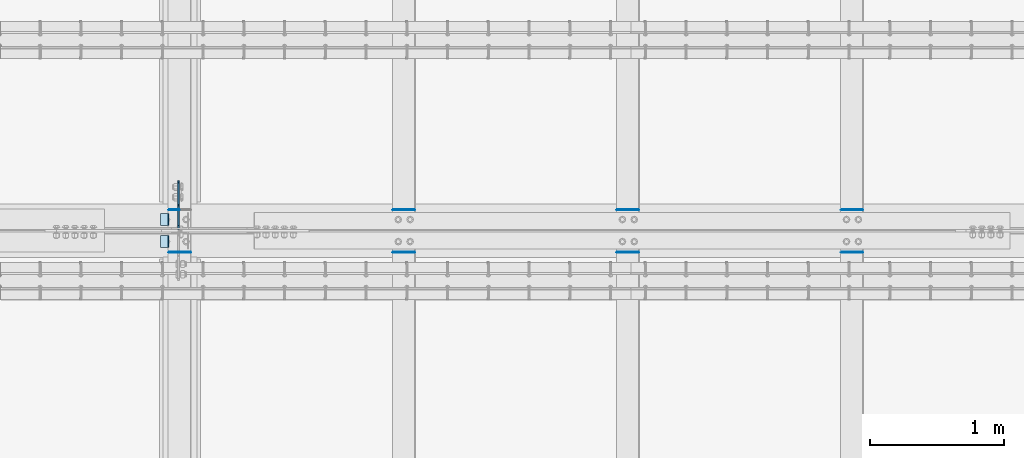
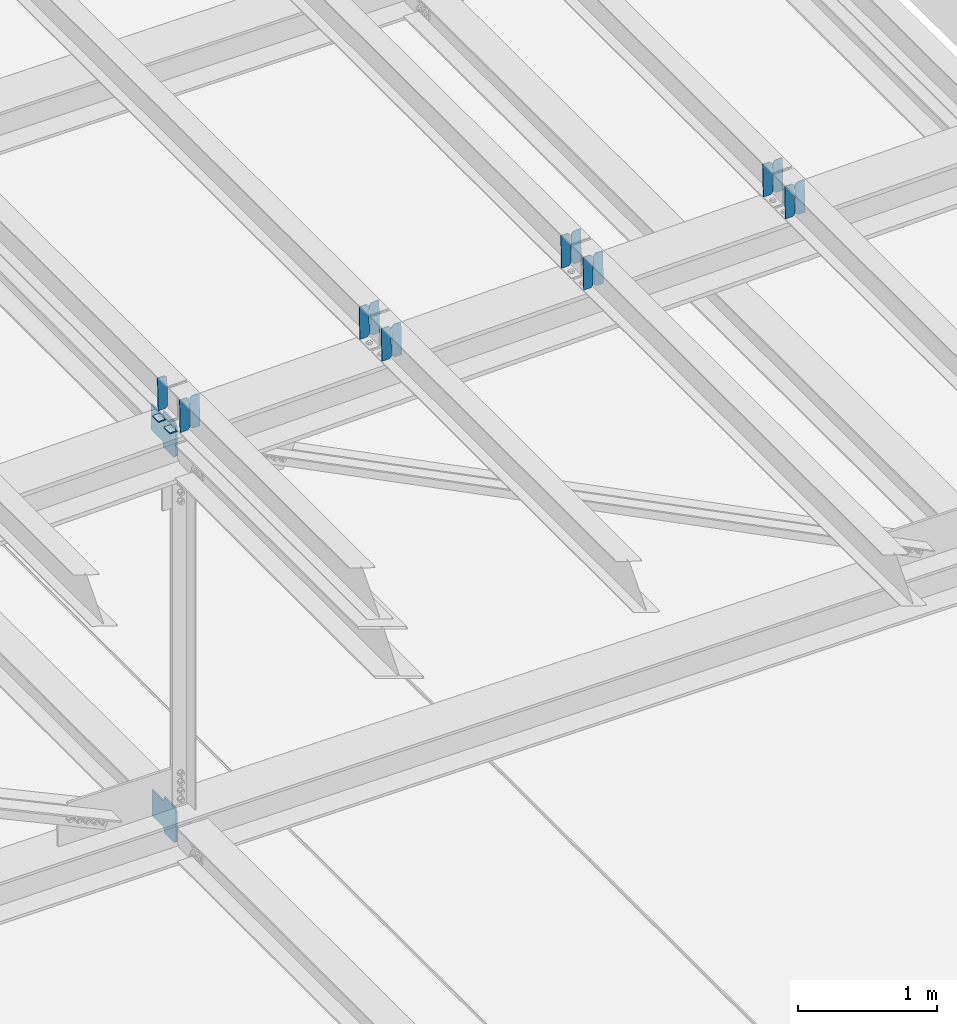
# One storey, part 3310 of 3843: 19 plates, 10 elements without a shape of their own.
"""IFC2X3 building model written with IfcOpenShell, lengths in millimetres."""

from ifc_helpers import new_model, si_unit, frame, origin_with_axes, place, context, subcontext, project, spatial, faceted_brep, material, type_object, element, aggregate, save


model = new_model("IFC2X3")

# Units and contexts
model_context = context("Model", 3, precision=1e-05, world=origin_with_axes())
body_context = subcontext(model_context, "Body", "Model", "MODEL_VIEW")
ifc_project = project(units=[si_unit("LENGTHUNIT", "METRE", prefix="MILLI"), si_unit("AREAUNIT", "SQUARE_METRE"), si_unit("VOLUMEUNIT", "CUBIC_METRE"), si_unit("MASSUNIT", "GRAM", prefix="KILO"), si_unit("TIMEUNIT", "SECOND"), si_unit("PLANEANGLEUNIT", "RADIAN"), si_unit("SOLIDANGLEUNIT", "STERADIAN"), si_unit("THERMODYNAMICTEMPERATUREUNIT", "DEGREE_CELSIUS"), si_unit("LUMINOUSINTENSITYUNIT", "LUMEN")], contexts=[model_context])

# Site, building, storey
site_placement = place(None, origin_with_axes())
site = spatial("IfcSite", under=ifc_project, at=site_placement, CompositionType="ELEMENT")
building_placement = place(site_placement, origin_with_axes())
building = spatial("IfcBuilding", under=site, at=building_placement, Name="Undefined", CompositionType="ELEMENT")
storey_placement = place(building_placement, origin_with_axes())
storey = spatial("IfcBuildingStorey", under=building, at=storey_placement, Name="Undefined", CompositionType="ELEMENT", Elevation=0.0)

# Assembly, plate
assembly_1_placement = place(storey_placement, origin_with_axes())
assembly_1 = element("IfcElementAssembly", 1, at=assembly_1_placement, inside=storey, Name="BEAM", AssemblyPlace="NOTDEFINED", PredefinedType="RIGID_FRAME")
ifc_material = material(Name="STEEL/A572-50")
plate_type_1 = type_object("IfcPlateType", PredefinedType="NOTDEFINED")
plate_1_placement = place(assembly_1_placement, frame((55927.3906576565, 59070.7910595311, 45923.7264285858), z_axis=(-0.0211520978350237, 0.000279663000066649, 0.999776230236438), x_axis=(-0.999776269348334, -6.33400000515396e-06, -0.0211520970073616)))
plate_1 = element("IfcPlate", 2, at=plate_1_placement, type_object=plate_type_1, material=ifc_material, Name="PLATE", context=body_context, shape_type="Brep", body=[
    faceted_brep([(4.36557456851006e-11, -3.17499999998836, 19.0499992370969), (6.11180439591408e-10, -3.17499999996653, 269.875000761516), (5.96628524363041e-10, 3.17500000001746, 269.875000761502), (1.45519152283669e-11, 3.17499999998836, 19.0499992370824), (19.0499992376572, -3.17500000003201, 288.924999998606), (19.0499992376281, 3.1749999999447, 288.924999998584), (79.3750000013242, -3.17500000025029, 288.924999998591), (79.3750000013097, 3.1749999997337, 288.92499999857), (79.3750000006548, -3.17500000026484, -2.18278728425503e-11), (79.3750000006403, 3.17499999969732, -2.91038304567337e-11), (19.0499992370023, -3.17500000005384, 0.0), (19.0499992369587, 3.17499999992287, -1.45519152283669e-11)], [[[0, 1, 2, 3]], [[1, 4, 5, 2]], [[4, 6, 7, 5]], [[6, 8, 9, 7]], [[8, 10, 11, 9]], [[10, 0, 3, 11]], [[5, 7, 9, 11, 3, 2]], [[10, 8, 6, 4, 1, 0]]]),
])

# Assembly, plates
assembly_2_placement = place(storey_placement, origin_with_axes())
assembly_2 = element("IfcElementAssembly", 3, at=assembly_2_placement, inside=storey, Name="BEAM", AssemblyPlace="NOTDEFINED", PredefinedType="RIGID_FRAME")
plate_2_placement = place(assembly_2_placement, frame((56013.0964782592, 58753.457365897, 45925.5384956644), z_axis=(-0.0211520978139451, -0.000276085000063176, 0.99977623123134), x_axis=(-0.999776269348334, 6.33400000515396e-06, -0.0211520970073544)))
plate_2 = element("IfcPlate", 4, at=plate_2_placement, type_object=plate_type_1, material=ifc_material, Name="PLATE", context=body_context, shape_type="Brep", body=[
    faceted_brep([(0.0, -3.17499999999927, 0.0), (6.83940015733242e-10, -3.17499999996653, 288.924999998613), (6.54836185276508e-10, 3.17500000001746, 288.924999998591), (0.0, 3.17499999999927, 0.0), (60.3250007643655, -3.17500000017753, 288.924999998606), (60.3250007643219, 3.17499999979918, 288.924999998584), (79.3750000013097, -3.17500000025029, 269.875000761494), (79.375000001266, 3.17499999972642, 269.875000761487), (79.375000000713, -3.17500000026484, 19.0499992370605), (79.3750000006985, 3.17499999971187, 19.0499992370533), (60.325000763667, -3.17500000020664, -1.45519152283669e-11), (60.3250007636234, 3.17499999977736, -3.63797880709171e-11)], [[[0, 1, 2, 3]], [[1, 4, 5, 2]], [[4, 6, 7, 5]], [[6, 8, 9, 7]], [[8, 10, 11, 9]], [[10, 0, 3, 11]], [[5, 7, 9, 11, 3, 2]], [[10, 8, 6, 4, 1, 0]]]),
])
plate_3_placement = place(assembly_2_placement, frame((55927.3906575696, 58753.4578666242, 45923.7252321319), z_axis=(-0.0211520978139451, -0.000276085000063176, 0.99977623123134), x_axis=(-0.999776269348334, 6.33400000515396e-06, -0.0211520970073544)))
plate_3 = element("IfcPlate", 5, at=plate_3_placement, type_object=plate_type_1, material=ifc_material, Name="PLATE", context=body_context, shape_type="Brep", body=[
    faceted_brep([(4.36557456851006e-11, -3.17499999998836, 19.0499992370969), (6.11180439591408e-10, -3.17499999996653, 269.875000761516), (5.96628524363041e-10, 3.17500000001746, 269.875000761502), (1.45519152283669e-11, 3.17499999998836, 19.0499992370824), (19.0499992376572, -3.17500000003201, 288.924999998606), (19.0499992376281, 3.1749999999447, 288.924999998584), (79.3750000013242, -3.17500000025029, 288.924999998591), (79.3750000013097, 3.1749999997337, 288.92499999857), (79.3750000006548, -3.17500000026484, -2.18278728425503e-11), (79.3750000006403, 3.17499999969732, -2.91038304567337e-11), (19.0499992370023, -3.17500000005384, 0.0), (19.0499992369587, 3.17499999992287, -1.45519152283669e-11)], [[[0, 1, 2, 3]], [[1, 4, 5, 2]], [[4, 6, 7, 5]], [[6, 8, 9, 7]], [[8, 10, 11, 9]], [[10, 0, 3, 11]], [[5, 7, 9, 11, 3, 2]], [[10, 8, 6, 4, 1, 0]]]),
])

assembly_3_placement = place(storey_placement, origin_with_axes())
assembly_3 = element("IfcElementAssembly", 6, at=assembly_3_placement, inside=storey, Name="BEAM", AssemblyPlace="NOTDEFINED", PredefinedType="RIGID_FRAME")
plate_4_placement = place(assembly_3_placement, frame((61042.296481751, 59070.7712281851, 46042.2801372535), z_axis=(-0.0211520982797228, 0.000347817999943799, 0.99977620883926), x_axis=(-0.999776269341478, -7.33700003415536e-06, -0.0211520970072466)))
plate_4 = element("IfcPlate", 7, at=plate_4_placement, type_object=plate_type_1, material=ifc_material, Name="PLATE", context=body_context, shape_type="Brep", body=[
    faceted_brep([(0.0, -3.17499999999927, 0.0), (6.83940015733242e-10, -3.17499999996653, 288.924999998613), (6.54836185276508e-10, 3.17500000001746, 288.924999998591), (0.0, 3.17499999999927, 0.0), (60.3250007643655, -3.17500000017753, 288.924999998606), (60.3250007643219, 3.17499999979918, 288.924999998584), (79.3750000013097, -3.17500000025029, 269.875000761494), (79.375000001266, 3.17499999972642, 269.875000761487), (79.375000000713, -3.17500000026484, 19.0499992370605), (79.3750000006985, 3.17499999971187, 19.0499992370533), (60.325000763667, -3.17500000020664, -1.45519152283669e-11), (60.3250007636234, 3.17499999977736, -3.63797880709171e-11)], [[[0, 1, 2, 3]], [[1, 4, 5, 2]], [[4, 6, 7, 5]], [[6, 8, 9, 7]], [[8, 10, 11, 9]], [[10, 0, 3, 11]], [[5, 7, 9, 11, 3, 2]], [[10, 8, 6, 4, 1, 0]]]),
])
plate_5_placement = place(assembly_3_placement, frame((60956.5906610613, 59070.7705992454, 46040.4668737616), z_axis=(-0.0211520982797228, 0.000347817999943799, 0.99977620883926), x_axis=(-0.999776269341478, -7.33700003415536e-06, -0.0211520970072466)))
plate_5 = element("IfcPlate", 8, at=plate_5_placement, type_object=plate_type_1, material=ifc_material, Name="PLATE", context=body_context, shape_type="Brep", body=[
    faceted_brep([(4.36557456851006e-11, -3.17499999998836, 19.0499992370969), (6.11180439591408e-10, -3.17499999996653, 269.875000761516), (5.96628524363041e-10, 3.17500000001746, 269.875000761502), (1.45519152283669e-11, 3.17499999998836, 19.0499992370824), (19.0499992376572, -3.17500000003201, 288.924999998606), (19.0499992376281, 3.1749999999447, 288.924999998584), (79.3750000013242, -3.17500000025029, 288.924999998591), (79.3750000013097, 3.1749999997337, 288.92499999857), (79.3750000006548, -3.17500000026484, -2.18278728425503e-11), (79.3750000006403, 3.17499999969732, -2.91038304567337e-11), (19.0499992370023, -3.17500000005384, 0.0), (19.0499992369587, 3.17499999992287, -1.45519152283669e-11)], [[[0, 1, 2, 3]], [[1, 4, 5, 2]], [[4, 6, 7, 5]], [[6, 8, 9, 7]], [[8, 10, 11, 9]], [[10, 0, 3, 11]], [[5, 7, 9, 11, 3, 2]], [[10, 8, 6, 4, 1, 0]]]),
])
aggregate(assembly_3, [plate_4, plate_5])

assembly_4_placement = place(storey_placement, origin_with_axes())
assembly_4 = element("IfcElementAssembly", 9, at=assembly_4_placement, inside=storey, Name="BEAM", AssemblyPlace="NOTDEFINED", PredefinedType="RIGID_FRAME")
plate_6_placement = place(assembly_4_placement, frame((61042.2964783208, 58753.4787211452, 46042.2779533499), z_axis=(-0.0211520982859365, -0.000347652999960701, 0.999776208896518), x_axis=(-0.999776269354799, 8.33600001439919e-06, -0.0211520960075334)))
plate_6 = element("IfcPlate", 10, at=plate_6_placement, type_object=plate_type_1, material=ifc_material, Name="PLATE", context=body_context, shape_type="Brep", body=[
    faceted_brep([(0.0, -3.17499999999927, 0.0), (6.83940015733242e-10, -3.17499999996653, 288.924999998613), (6.54836185276508e-10, 3.17500000001746, 288.924999998591), (0.0, 3.17499999999927, 0.0), (60.3250007643655, -3.17500000017753, 288.924999998606), (60.3250007643219, 3.17499999979918, 288.924999998584), (79.3750000013097, -3.17500000025029, 269.875000761494), (79.375000001266, 3.17499999972642, 269.875000761487), (79.375000000713, -3.17500000026484, 19.0499992370605), (79.3750000006985, 3.17499999971187, 19.0499992370533), (60.325000763667, -3.17500000020664, -1.45519152283669e-11), (60.3250007636234, 3.17499999977736, -3.63797880709171e-11)], [[[0, 1, 2, 3]], [[1, 4, 5, 2]], [[4, 6, 7, 5]], [[6, 8, 9, 7]], [[8, 10, 11, 9]], [[10, 0, 3, 11]], [[5, 7, 9, 11, 3, 2]], [[10, 8, 6, 4, 1, 0]]]),
])
plate_7_placement = place(assembly_4_placement, frame((60956.5906576314, 58753.4793516735, 46040.4646898588), z_axis=(-0.0211520982859365, -0.000347652999960701, 0.999776208896518), x_axis=(-0.999776269354799, 8.33600001439919e-06, -0.0211520960075334)))
plate_7 = element("IfcPlate", 11, at=plate_7_placement, type_object=plate_type_1, material=ifc_material, Name="PLATE", context=body_context, shape_type="Brep", body=[
    faceted_brep([(4.36557456851006e-11, -3.17499999998836, 19.0499992370969), (6.11180439591408e-10, -3.17499999996653, 269.875000761516), (5.96628524363041e-10, 3.17500000001746, 269.875000761502), (1.45519152283669e-11, 3.17499999998836, 19.0499992370824), (19.0499992376572, -3.17500000003201, 288.924999998606), (19.0499992376281, 3.1749999999447, 288.924999998584), (79.3750000013242, -3.17500000025029, 288.924999998591), (79.3750000013097, 3.1749999997337, 288.92499999857), (79.3750000006548, -3.17500000026484, -2.18278728425503e-11), (79.3750000006403, 3.17499999969732, -2.91038304567337e-11), (19.0499992370023, -3.17500000005384, 0.0), (19.0499992369587, 3.17499999992287, -1.45519152283669e-11)], [[[0, 1, 2, 3]], [[1, 4, 5, 2]], [[4, 6, 7, 5]], [[6, 8, 9, 7]], [[8, 10, 11, 9]], [[10, 0, 3, 11]], [[5, 7, 9, 11, 3, 2]], [[10, 8, 6, 4, 1, 0]]]),
])
aggregate(assembly_4, [plate_6, plate_7])

assembly_5_placement = place(storey_placement, origin_with_axes())
assembly_5 = element("IfcElementAssembly", 12, at=assembly_5_placement, inside=storey, Name="BEAM", AssemblyPlace="NOTDEFINED", PredefinedType="RIGID_FRAME")
plate_8_placement = place(assembly_5_placement, frame((59365.8964817423, 59070.7737371249, 46004.0262619448), z_axis=(-0.021152098218743, 0.00033940999990591, 0.999776211730304), x_axis=(-0.999776269348334, -6.33400000515396e-06, -0.0211520970073616)))
plate_8 = element("IfcPlate", 13, at=plate_8_placement, type_object=plate_type_1, material=ifc_material, Name="PLATE", context=body_context, shape_type="Brep", body=[
    faceted_brep([(0.0, -3.17499999999927, 0.0), (6.83940015733242e-10, -3.17499999996653, 288.924999998613), (6.54836185276508e-10, 3.17500000001746, 288.924999998591), (0.0, 3.17499999999927, 0.0), (60.3250007643655, -3.17500000017753, 288.924999998606), (60.3250007643219, 3.17499999979918, 288.924999998584), (79.3750000013097, -3.17500000025029, 269.875000761494), (79.375000001266, 3.17499999972642, 269.875000761487), (79.375000000713, -3.17500000026484, 19.0499992370605), (79.3750000006985, 3.17499999971187, 19.0499992370533), (60.325000763667, -3.17500000020664, -1.45519152283669e-11), (60.3250007636234, 3.17499999977736, -3.63797880709171e-11)], [[[0, 1, 2, 3]], [[1, 4, 5, 2]], [[4, 6, 7, 5]], [[6, 8, 9, 7]], [[8, 10, 11, 9]], [[10, 0, 3, 11]], [[5, 7, 9, 11, 3, 2]], [[10, 8, 6, 4, 1, 0]]]),
])
plate_9_placement = place(assembly_5_placement, frame((59280.1906610515, 59070.773123433, 46002.2129984481), z_axis=(-0.021152098218743, 0.00033940999990591, 0.999776211730304), x_axis=(-0.999776269348334, -6.33400000515396e-06, -0.0211520970073616)))
plate_9 = element("IfcPlate", 14, at=plate_9_placement, type_object=plate_type_1, material=ifc_material, Name="PLATE", context=body_context, shape_type="Brep", body=[
    faceted_brep([(4.36557456851006e-11, -3.17499999998836, 19.0499992370969), (6.11180439591408e-10, -3.17499999996653, 269.875000761516), (5.96628524363041e-10, 3.17500000001746, 269.875000761502), (1.45519152283669e-11, 3.17499999998836, 19.0499992370824), (19.0499992376572, -3.17500000003201, 288.924999998606), (19.0499992376281, 3.1749999999447, 288.924999998584), (79.3750000013242, -3.17500000025029, 288.924999998591), (79.3750000013097, 3.1749999997337, 288.92499999857), (79.3750000006548, -3.17500000026484, -2.18278728425503e-11), (79.3750000006403, 3.17499999969732, -2.91038304567337e-11), (19.0499992370023, -3.17500000005384, 0.0), (19.0499992369587, 3.17499999992287, -1.45519152283669e-11)], [[[0, 1, 2, 3]], [[1, 4, 5, 2]], [[4, 6, 7, 5]], [[6, 8, 9, 7]], [[8, 10, 11, 9]], [[10, 0, 3, 11]], [[5, 7, 9, 11, 3, 2]], [[10, 8, 6, 4, 1, 0]]]),
])
aggregate(assembly_5, [plate_8, plate_9])

assembly_6_placement = place(storey_placement, origin_with_axes())
assembly_6 = element("IfcElementAssembly", 15, at=assembly_6_placement, inside=storey, Name="BEAM", AssemblyPlace="NOTDEFINED", PredefinedType="RIGID_FRAME")
plate_10_placement = place(assembly_6_placement, frame((59365.8964782968, 58753.4766526305, 46004.0238911764), z_axis=(-0.0211520982357469, -0.000340721000095072, 0.999776211284018), x_axis=(-0.999776269348334, 6.33400000515396e-06, -0.0211520970073544)))
plate_10 = element("IfcPlate", 16, at=plate_10_placement, type_object=plate_type_1, material=ifc_material, Name="PLATE", context=body_context, shape_type="Brep", body=[
    faceted_brep([(0.0, -3.17499999999927, 0.0), (6.83940015733242e-10, -3.17499999996653, 288.924999998613), (6.54836185276508e-10, 3.17500000001746, 288.924999998591), (0.0, 3.17499999999927, 0.0), (60.3250007643655, -3.17500000017753, 288.924999998606), (60.3250007643219, 3.17499999979918, 288.924999998584), (79.3750000013097, -3.17500000025029, 269.875000761494), (79.375000001266, 3.17499999972642, 269.875000761487), (79.375000000713, -3.17500000026484, 19.0499992370605), (79.3750000006985, 3.17499999971187, 19.0499992370533), (60.325000763667, -3.17500000020664, -1.45519152283669e-11), (60.3250007636234, 3.17499999977736, -3.63797880709171e-11)], [[[0, 1, 2, 3]], [[1, 4, 5, 2]], [[4, 6, 7, 5]], [[6, 8, 9, 7]], [[8, 10, 11, 9]], [[10, 0, 3, 11]], [[5, 7, 9, 11, 3, 2]], [[10, 8, 6, 4, 1, 0]]]),
])
plate_11_placement = place(assembly_6_placement, frame((59280.1906576074, 58753.4772705848, 46002.2106276802), z_axis=(-0.0211520982357469, -0.000340721000095072, 0.999776211284018), x_axis=(-0.999776269348334, 6.33400000515396e-06, -0.0211520970073544)))
plate_11 = element("IfcPlate", 17, at=plate_11_placement, type_object=plate_type_1, material=ifc_material, Name="PLATE", context=body_context, shape_type="Brep", body=[
    faceted_brep([(4.36557456851006e-11, -3.17499999998836, 19.0499992370969), (6.11180439591408e-10, -3.17499999996653, 269.875000761516), (5.96628524363041e-10, 3.17500000001746, 269.875000761502), (1.45519152283669e-11, 3.17499999998836, 19.0499992370824), (19.0499992376572, -3.17500000003201, 288.924999998606), (19.0499992376281, 3.1749999999447, 288.924999998584), (79.3750000013242, -3.17500000025029, 288.924999998591), (79.3750000013097, 3.1749999997337, 288.92499999857), (79.3750000006548, -3.17500000026484, -2.18278728425503e-11), (79.3750000006403, 3.17499999969732, -2.91038304567337e-11), (19.0499992370023, -3.17500000005384, 0.0), (19.0499992369587, 3.17499999992287, -1.45519152283669e-11)], [[[0, 1, 2, 3]], [[1, 4, 5, 2]], [[4, 6, 7, 5]], [[6, 8, 9, 7]], [[8, 10, 11, 9]], [[10, 0, 3, 11]], [[5, 7, 9, 11, 3, 2]], [[10, 8, 6, 4, 1, 0]]]),
])
aggregate(assembly_6, [plate_10, plate_11])

assembly_7_placement = place(storey_placement, origin_with_axes())
assembly_7 = element("IfcElementAssembly", 18, at=assembly_7_placement, inside=storey, Name="BEAM", AssemblyPlace="NOTDEFINED", PredefinedType="RIGID_FRAME")
plate_12_placement = place(assembly_7_placement, frame((57689.4964736388, 59070.7829263739, 45965.0127834056), z_axis=(-0.0211520980146961, 0.000308619999916118, 0.999776221713275), x_axis=(-0.999776269348334, -6.33400000515396e-06, -0.0211520970073616)))
plate_12 = element("IfcPlate", 19, at=plate_12_placement, type_object=plate_type_1, material=ifc_material, Name="PLATE", context=body_context, shape_type="Brep", body=[
    faceted_brep([(0.0, -3.17499999999927, 0.0), (6.83940015733242e-10, -3.17499999996653, 288.924999998613), (6.54836185276508e-10, 3.17500000001746, 288.924999998591), (0.0, 3.17499999999927, 0.0), (60.3250007643655, -3.17500000017753, 288.924999998606), (60.3250007643219, 3.17499999979918, 288.924999998584), (79.3750000013097, -3.17500000025029, 269.875000761494), (79.375000001266, 3.17499999972642, 269.875000761487), (79.375000000713, -3.17500000026484, 19.0499992370605), (79.3750000006985, 3.17499999971187, 19.0499992370533), (60.325000763667, -3.17500000020664, -1.45519152283669e-11), (60.3250007636234, 3.17499999977736, -3.63797880709171e-11)], [[[0, 1, 2, 3]], [[1, 4, 5, 2]], [[4, 6, 7, 5]], [[6, 8, 9, 7]], [[8, 10, 11, 9]], [[10, 0, 3, 11]], [[5, 7, 9, 11, 3, 2]], [[10, 8, 6, 4, 1, 0]]]),
])
plate_13_placement = place(assembly_7_placement, frame((57603.7906529491, 59070.7823667252, 45963.1995198909), z_axis=(-0.0211520980146961, 0.000308619999916118, 0.999776221713275), x_axis=(-0.999776269348334, -6.33400000515396e-06, -0.0211520970073616)))
plate_13 = element("IfcPlate", 20, at=plate_13_placement, type_object=plate_type_1, material=ifc_material, Name="PLATE", context=body_context, shape_type="Brep", body=[
    faceted_brep([(4.36557456851006e-11, -3.17499999998836, 19.0499992370969), (6.11180439591408e-10, -3.17499999996653, 269.875000761516), (5.96628524363041e-10, 3.17500000001746, 269.875000761502), (1.45519152283669e-11, 3.17499999998836, 19.0499992370824), (19.0499992376572, -3.17500000003201, 288.924999998606), (19.0499992376281, 3.1749999999447, 288.924999998584), (79.3750000013242, -3.17500000025029, 288.924999998591), (79.3750000013097, 3.1749999997337, 288.92499999857), (79.3750000006548, -3.17500000026484, -2.18278728425503e-11), (79.3750000006403, 3.17499999969732, -2.91038304567337e-11), (19.0499992370023, -3.17500000005384, 0.0), (19.0499992369587, 3.17499999992287, -1.45519152283669e-11)], [[[0, 1, 2, 3]], [[1, 4, 5, 2]], [[4, 6, 7, 5]], [[6, 8, 9, 7]], [[8, 10, 11, 9]], [[10, 0, 3, 11]], [[5, 7, 9, 11, 3, 2]], [[10, 8, 6, 4, 1, 0]]]),
])
aggregate(assembly_7, [plate_12, plate_13])

assembly_8_placement = place(storey_placement, origin_with_axes())
assembly_8 = element("IfcElementAssembly", 21, at=assembly_8_placement, inside=storey, Name="BEAM", AssemblyPlace="NOTDEFINED", PredefinedType="RIGID_FRAME")
plate_14_placement = place(assembly_8_placement, frame((57689.4964700904, 58753.4659194598, 45965.0114503967), z_axis=(-0.0211520979898778, -0.000304750999974203, 0.999776222900632), x_axis=(-0.999776269348334, 6.33400000515396e-06, -0.0211520970073544)))
plate_14 = element("IfcPlate", 22, at=plate_14_placement, type_object=plate_type_1, material=ifc_material, Name="PLATE", context=body_context, shape_type="Brep", body=[
    faceted_brep([(0.0, -3.17499999999927, 0.0), (6.83940015733242e-10, -3.17499999996653, 288.924999998613), (6.54836185276508e-10, 3.17500000001746, 288.924999998591), (0.0, 3.17499999999927, 0.0), (60.3250007643655, -3.17500000017753, 288.924999998606), (60.3250007643219, 3.17499999979918, 288.924999998584), (79.3750000013097, -3.17500000025029, 269.875000761494), (79.375000001266, 3.17499999972642, 269.875000761487), (79.375000000713, -3.17500000026484, 19.0499992370605), (79.3750000006985, 3.17499999971187, 19.0499992370533), (60.325000763667, -3.17500000020664, -1.45519152283669e-11), (60.3250007636234, 3.17499999977736, -3.63797880709171e-11)], [[[0, 1, 2, 3]], [[1, 4, 5, 2]], [[4, 6, 7, 5]], [[6, 8, 9, 7]], [[8, 10, 11, 9]], [[10, 0, 3, 11]], [[5, 7, 9, 11, 3, 2]], [[10, 8, 6, 4, 1, 0]]]),
])
plate_15_placement = place(assembly_8_placement, frame((57603.7906494011, 58753.4664720917, 45963.1981868798), z_axis=(-0.0211520979898778, -0.000304750999974203, 0.999776222900632), x_axis=(-0.999776269348334, 6.33400000515396e-06, -0.0211520970073544)))
plate_15 = element("IfcPlate", 23, at=plate_15_placement, type_object=plate_type_1, material=ifc_material, Name="PLATE", context=body_context, shape_type="Brep", body=[
    faceted_brep([(4.36557456851006e-11, -3.17499999998836, 19.0499992370969), (6.11180439591408e-10, -3.17499999996653, 269.875000761516), (5.96628524363041e-10, 3.17500000001746, 269.875000761502), (1.45519152283669e-11, 3.17499999998836, 19.0499992370824), (19.0499992376572, -3.17500000003201, 288.924999998606), (19.0499992376281, 3.1749999999447, 288.924999998584), (79.3750000013242, -3.17500000025029, 288.924999998591), (79.3750000013097, 3.1749999997337, 288.92499999857), (79.3750000006548, -3.17500000026484, -2.18278728425503e-11), (79.3750000006403, 3.17499999969732, -2.91038304567337e-11), (19.0499992370023, -3.17500000005384, 0.0), (19.0499992369587, 3.17499999992287, -1.45519152283669e-11)], [[[0, 1, 2, 3]], [[1, 4, 5, 2]], [[4, 6, 7, 5]], [[6, 8, 9, 7]], [[8, 10, 11, 9]], [[10, 0, 3, 11]], [[5, 7, 9, 11, 3, 2]], [[10, 8, 6, 4, 1, 0]]]),
])
aggregate(assembly_8, [plate_14, plate_15])

# Plate
plate_type_2 = type_object("IfcPlateType", PredefinedType="NOTDEFINED")
plate_16_placement = place(assembly_1_placement, frame((55848.167731939, 59042.3, 45915.7424021228), z_axis=(0.0, -1.0, 0.0), x_axis=(-0.999776270257024, 0.0, -0.0211520550054595)))
plate_16 = element("IfcPlate", 24, at=plate_16_placement, type_object=plate_type_2, material=ifc_material, Name="PLATE", context=body_context, shape_type="Brep", body=[
    faceted_brep([(9.52499999982683, -4.7625000001135, 88.8999999999942), (0.0, 4.76249999999709, 88.9000015258789), (0.0, 4.76249999999709, 0.0), (9.52499999981956, -4.76249999999709, 0.0), (63.4999984608512, -4.76249999988795, 88.8999999999796), (63.4999984608367, -4.76249999988795, -1.45519152283669e-11), (63.4999984608221, 4.76250000013533, -1.45519152283669e-11), (63.4999984608367, 4.76250000013533, 88.8999999999796)], [[[0, 1, 2, 3]], [[4, 5, 6, 7]], [[5, 4, 0, 3]], [[6, 5, 3, 2]], [[7, 6, 2, 1]], [[4, 7, 1, 0]]]),
])

aggregate(assembly_1, [plate_1, plate_16])

plate_17_placement = place(assembly_2_placement, frame((55848.167731939, 58877.2000015258, 45915.7424021228), z_axis=(0.0, -1.0, 0.0), x_axis=(-0.999776270257024, 0.0, -0.0211520550054595)))
plate_17 = element("IfcPlate", 25, at=plate_17_placement, type_object=plate_type_2, material=ifc_material, Name="PLATE", context=body_context, shape_type="Brep", body=[
    faceted_brep([(9.52499999982683, -4.7625000001135, 88.8999999999942), (0.0, 4.76249999999709, 88.9000015258789), (0.0, 4.76249999999709, 0.0), (9.52499999981956, -4.76249999999709, 0.0), (63.4999984608512, -4.76249999988795, 88.8999999999796), (63.4999984608367, -4.76249999988795, -1.45519152283669e-11), (63.4999984608221, 4.76250000013533, -1.45519152283669e-11), (63.4999984608367, 4.76250000013533, 88.8999999999796)], [[[0, 1, 2, 3]], [[4, 5, 6, 7]], [[5, 4, 0, 3]], [[6, 5, 3, 2]], [[7, 6, 2, 1]], [[4, 7, 1, 0]]]),
])

aggregate(assembly_2, [plate_2, plate_3, plate_17])

# Assembly, plate
assembly_9_placement = place(storey_placement, origin_with_axes())
assembly_9 = element("IfcElementAssembly", 26, at=assembly_9_placement, inside=storey, Name="BEAM", AssemblyPlace="NOTDEFINED", PredefinedType="RIGID_FRAME")
plate_type_3 = type_object("IfcPlateType", PredefinedType="NOTDEFINED")
plate_18_placement = place(assembly_9_placement, frame((55919.6874999247, 58922.44375, 42204.3461847859), z_axis=(0.0, 0.707106781186548, 0.707106781186548), x_axis=(5.70000238222118e-08, 0.707106781186546, -0.707106781186546)))
plate_18 = element("IfcPlate", 27, at=plate_18_placement, type_object=plate_type_3, material=ifc_material, Name="PLATE", context=body_context, shape_type="Brep", body=[
    faceted_brep([(0.0, -6.3499999046162, 0.0), (-179.583001153514, -6.34999999999854, 179.583001153513), (-179.583001153514, 6.34999999999854, 179.583001153513), (7.27595761418343e-12, 6.3499999046162, 0.0), (-179.5830011535, -6.34999999999854, 224.484281758638), (-179.5830011535, 6.34999999999854, 224.484281758638), (-75.7487897469837, -6.34999999999854, 328.318493165172), (-75.7487897469837, 6.34999999999854, 328.318493165172), (-53.2815138136193, -6.34999999999854, 305.851217217496), (-53.2815138136193, 6.34999999999854, 305.851217217496), (-49.1613373454693, -6.34999999999854, 303.098203317029), (-49.1613373454693, 6.34999999999854, 303.098203317029), (-44.3012578274411, -6.34999999999854, 302.131473394431), (-44.3012578274411, 6.34999999999854, 302.131473394431), (-39.4411783094056, -6.34999999999854, 303.098203317029), (-39.4411783094056, 6.34999999999854, 303.098203317029), (-35.3210018412628, -6.34999999999854, 305.851217217496), (-35.3210018412628, 6.34999999999854, 305.851217217496), (76.9321998064024, -6.34999999999854, 418.104418865143), (76.9321998064024, 6.34999999999854, 418.104418865143), (238.576809984866, -6.34999999999854, 256.45980868669), (238.576809984866, 6.34999999999854, 256.45980868669), (126.323608337208, -6.34999999999854, 144.206607039028), (126.323608337208, 6.34999999999854, 144.206607039028), (123.570594436738, -6.34999999999854, 140.086430570882), (123.570594436738, 6.34999999999854, 140.086430570882), (122.603864514151, -6.34999999999854, 135.226351052843), (122.603864514151, 6.34999999999854, 135.226351052843), (123.570594436738, -6.34999999999854, 130.366271534818), (123.570594436738, 6.34999999999854, 130.366271534818), (126.323608337208, -6.34999999999854, 126.246095066657), (126.323608337208, 6.34999999999854, 126.246095066657), (148.735492004496, -6.35000000000582, 103.834211399357), (148.735492004496, 6.35000000000582, 103.834211399357), (44.9012806051323, -6.35000000000582, -1.45519152283669e-11), (44.9012806051323, 6.35000000000582, -1.45519152283669e-11)], [[[0, 1, 2, 3]], [[1, 4, 5, 2]], [[4, 6, 7, 5]], [[6, 8, 9, 7]], [[8, 10, 11, 9]], [[10, 12, 13, 11]], [[12, 14, 15, 13]], [[14, 16, 17, 15]], [[16, 18, 19, 17]], [[18, 20, 21, 19]], [[20, 22, 23, 21]], [[22, 24, 25, 23]], [[24, 26, 27, 25]], [[26, 28, 29, 27]], [[28, 30, 31, 29]], [[30, 32, 33, 31]], [[32, 34, 35, 33]], [[34, 0, 3, 35]], [[5, 7, 9, 11, 13, 15, 17, 19, 21, 23, 25, 27, 29, 31, 33, 35, 3, 2]], [[34, 32, 30, 28, 26, 24, 22, 20, 18, 16, 14, 12, 10, 8, 6, 4, 1, 0]]]),
])
aggregate(assembly_9, [plate_18])

assembly_10_placement = place(storey_placement, origin_with_axes())
assembly_10 = element("IfcElementAssembly", 28, at=assembly_10_placement, inside=storey, Name="BEAM", AssemblyPlace="NOTDEFINED", PredefinedType="RIGID_FRAME")
plate_19_placement = place(assembly_10_placement, frame((55919.6874998839, 58926.4125, 45588.6660822376), z_axis=(0.0, 0.707106781186548, 0.707106781186548), x_axis=(5.70000238222118e-08, 0.707106781186546, -0.707106781186546)))
plate_19 = element("IfcPlate", 29, at=plate_19_placement, type_object=plate_type_3, material=ifc_material, Name="PLATE", context=body_context, shape_type="Brep", body=[
    faceted_brep([(0.0, -6.3499999046162, 0.0), (-179.455423114094, -6.34999999999854, 179.45542311405), (-179.455423114094, 6.34999999999854, 179.45542311405), (7.27595761418343e-12, 6.3499999046162, 0.0), (-179.455423114079, -6.34999999999854, 224.356703719179), (-179.455423114079, 6.34999999999854, 224.356703719179), (-68.3247536059207, -6.34999999999854, 335.487373227363), (-68.3247536059207, 6.34999999999854, 335.487373227363), (-46.0835105054921, -6.34999999999854, 313.246130105996), (-46.0835105054921, 6.34999999999854, 313.246130105996), (-41.9633340373421, -6.34999999999854, 310.493116205529), (-41.9633340373421, 6.34999999999854, 310.493116205529), (-37.1032545193139, -6.34999999999854, 309.526386282931), (-37.1032545193139, 6.34999999999854, 309.526386282931), (-32.2431750012784, -6.34999999999854, 310.493116205529), (-32.2431750012784, 6.34999999999854, 310.493116205529), (-28.1229985331356, -6.34999999999854, 313.246130105996), (-28.1229985331356, 6.34999999999854, 313.246130105996), (84.1302031145478, -6.34999999999854, 425.499331753672), (84.1302031145478, 6.34999999999854, 425.499331753672), (245.774813293012, -6.34999999999854, 263.854721575204), (245.774813293012, 6.34999999999854, 263.854721575204), (133.521611645332, -6.34999999999854, 151.601519927528), (133.521611645332, 6.34999999999854, 151.601519927528), (130.768597744862, -6.34999999999854, 147.481343459382), (130.768597744862, 6.34999999999854, 147.481343459382), (129.801867822271, -6.34999999999854, 142.621263941357), (129.801867822271, 6.34999999999854, 142.621263941357), (130.768597744862, -6.34999999999854, 137.761184423318), (130.768597744862, 6.34999999999854, 137.761184423318), (133.521611645328, -6.34999999999854, 133.641007955172), (133.521611645328, 6.34999999999854, 133.641007955172), (156.031950102829, -6.35000000000582, 111.130669497703), (156.031950102829, 6.35000000000582, 111.130669497703), (44.9012806051323, -6.35000000000582, -1.45519152283669e-11), (44.9012806051323, 6.35000000000582, -1.45519152283669e-11)], [[[0, 1, 2, 3]], [[1, 4, 5, 2]], [[4, 6, 7, 5]], [[6, 8, 9, 7]], [[8, 10, 11, 9]], [[10, 12, 13, 11]], [[12, 14, 15, 13]], [[14, 16, 17, 15]], [[16, 18, 19, 17]], [[18, 20, 21, 19]], [[20, 22, 23, 21]], [[22, 24, 25, 23]], [[24, 26, 27, 25]], [[26, 28, 29, 27]], [[28, 30, 31, 29]], [[30, 32, 33, 31]], [[32, 34, 35, 33]], [[34, 0, 3, 35]], [[5, 7, 9, 11, 13, 15, 17, 19, 21, 23, 25, 27, 29, 31, 33, 35, 3, 2]], [[34, 32, 30, 28, 26, 24, 22, 20, 18, 16, 14, 12, 10, 8, 6, 4, 1, 0]]]),
])
aggregate(assembly_10, [plate_19])

save(model, "model.ifc")
